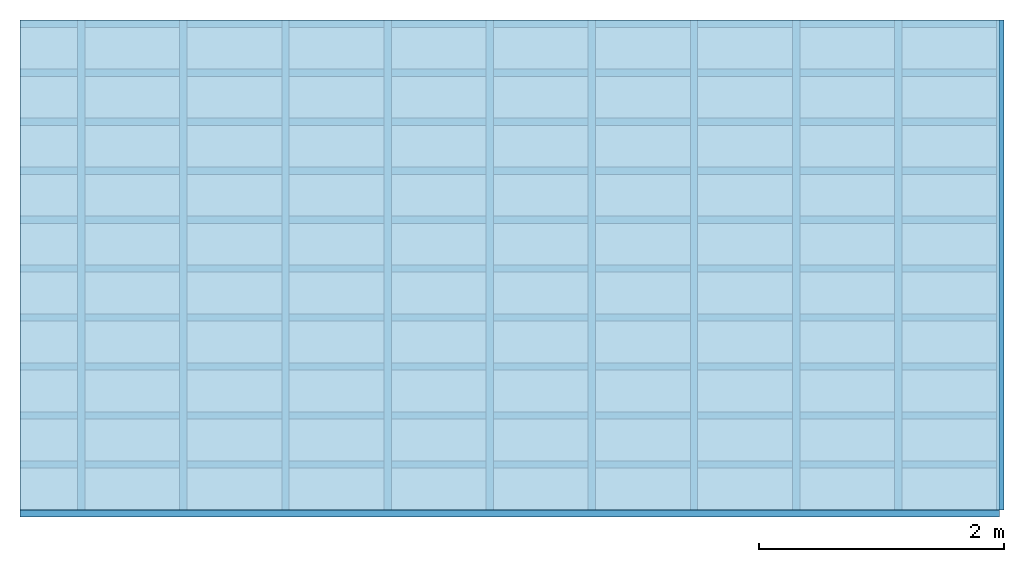
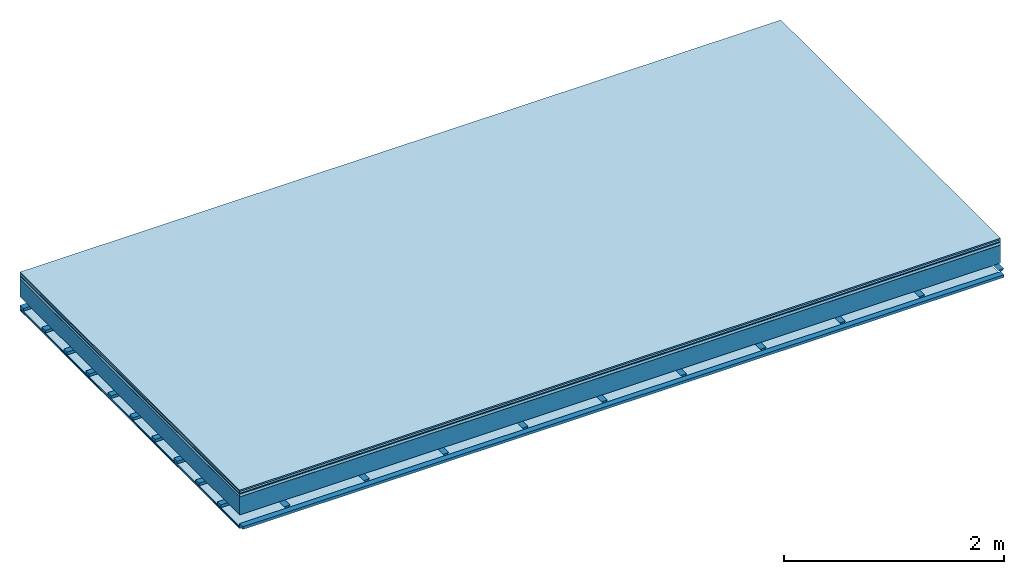
# One storey: 8 plates, 3 members, 1 element without a shape of its own.
"""IFC4 building model written with IfcOpenShell, lengths in metres."""

from ifc_helpers import new_model, si_unit, derived_unit, direction, frame, frame_2d, origin, origin_with_axes, place, context, project, spatial, polyline, rectangle, outline, extrude, material, layer, layer_set, type_object, element, aggregate, save


model = new_model("IFC4")

# Units and contexts
plan_context = context("Plan", 3, precision=1e-05, world=origin(), true_north=direction((0.0, 1.0)))
model_context = context("Model", 3, precision=1e-05, world=origin(), true_north=direction((0.0, 1.0)))
ifc_project = project(units=[si_unit("LENGTHUNIT", "METRE"), derived_unit("SOUNDPRESSUREUNIT", [(si_unit("PRESSUREUNIT", "PASCAL", prefix="MICRO"), 0)]), si_unit("ENERGYUNIT", "JOULE", prefix="MEGA"), si_unit("MASSUNIT", "GRAM", prefix="KILO"), derived_unit("THERMALTRANSMITTANCEUNIT", [(si_unit("POWERUNIT", "WATT"), 1), (si_unit("AREAUNIT", "SQUARE_METRE"), -1), (si_unit("THERMODYNAMICTEMPERATUREUNIT", "KELVIN"), -1)]), derived_unit("AREADENSITYUNIT", [(si_unit("MASSUNIT", "GRAM", prefix="KILO"), 1), (si_unit("AREAUNIT", "SQUARE_METRE"), -1)]), derived_unit("USERDEFINED", [(si_unit("ENERGYUNIT", "JOULE", prefix="MEGA"), 1), (si_unit("AREAUNIT", "SQUARE_METRE"), -1)])], contexts=[plan_context, model_context])

# Site, building, storey
site = spatial("IfcSite", under=ifc_project)
building_placement = place(None, origin())
building = spatial("IfcBuilding", under=site, at=building_placement)
storey_placement = place(building_placement, origin())
storey = spatial("IfcBuildingStorey", under=building, at=storey_placement)

# Slab, members, plates
ifc_material_1 = material(Category="11.013")
ifc_layer_1 = layer(ifc_material_1, 0.015, Name="Flooring")
ifc_material_2 = material(Category="03.007")
ifc_layer_2 = layer(ifc_material_2, 0.02, Name="On-material")
ifc_material_3 = material(Name="Wood fiber generic product", Category="10.009")
ifc_layer_3 = layer(ifc_material_3, 0.01, Name="Impact sound insulation")
ifc_material_4 = material(Name="with broken")
ifc_layer_4 = layer(ifc_material_4, 0.03, Name="on Supporting structure")
ifc_material_5 = material(Name="protection", Category="09.007")
ifc_layer_5 = layer(ifc_material_5, 0.0005, Name="Sub-floor")
ifc_material_6 = material(Name="no composite action")
ifc_layer_6 = layer(ifc_material_6, 0.0, Name="Bond")
ifc_layer_7 = layer(None, 0.2, Name="Supporting structure")
ifc_layer_8 = layer(ifc_material_6, 0.0, Name="Bond")
ifc_layer_9 = layer(None, 0.095, Name="Coupling")
ifc_layer_10 = layer(None, 0.03, Name="Battens / profiles")
ifc_material_7 = material(Name="Plasterboard type A", Category="03.008")
ifc_layer_11 = layer(ifc_material_7, 0.0125, Name="Ceiling covering 1st layer")
ifc_layer_12 = layer(ifc_material_7, 0.0125, Name="Ceiling covering layer 2")
ifc_material_8 = material(Category="04.001")
ifc_layer_13 = layer(ifc_material_8, 0.003, Name="Surface / treatment")
ifc_layer_set = layer_set([ifc_layer_1, ifc_layer_2, ifc_layer_3, ifc_layer_4, ifc_layer_5, ifc_layer_6, ifc_layer_7, ifc_layer_8, ifc_layer_9, ifc_layer_10, ifc_layer_11, ifc_layer_12, ifc_layer_13])
slab_type = type_object("IfcSlabType", Name="A2118", PredefinedType="NOTDEFINED", material=ifc_layer_set)
slab_placement = place(None, frame((0.0, 0.0, 0.0), z_axis=(0.0, 0.0, -1.0), x_axis=(1.0, 0.0, 0.0)))
slab = element("IfcSlab", 1, at=slab_placement, inside=storey, type_object=slab_type, material=ifc_layer_set, Name="Slab #1")
ifc_material_9 = material(Name="Solid timber panel")
member_1_placement = place(slab_placement, origin())
member_1 = element("IfcMember", 2, at=member_1_placement, material=ifc_material_9, Name="Supporting structure", context=plan_context, shape_type="SweptSolid", body=[
    extrude(rectangle(XDim=1.0, YDim=0.2, at=frame_2d((0.5, 0.1), x_axis=(1.0, 0.0))), frame((0.0, 4.0, 0.0755), z_axis=(0.0, -1.0, 0.0), x_axis=(1.0, 0.0, 0.0)), (0.0, 0.0, 1.0), 4.0),
    extrude(rectangle(XDim=1.0, YDim=0.2, at=frame_2d((0.5, 0.1), x_axis=(1.0, 0.0))), frame((1.0, 4.0, 0.0755), z_axis=(0.0, -1.0, 0.0), x_axis=(1.0, 0.0, 0.0)), (0.0, 0.0, 1.0), 4.0),
    extrude(rectangle(XDim=1.0, YDim=0.2, at=frame_2d((0.5, 0.1), x_axis=(1.0, 0.0))), frame((2.0, 4.0, 0.0755), z_axis=(0.0, -1.0, 0.0), x_axis=(1.0, 0.0, 0.0)), (0.0, 0.0, 1.0), 4.0),
    extrude(rectangle(XDim=1.0, YDim=0.2, at=frame_2d((0.5, 0.1), x_axis=(1.0, 0.0))), frame((3.0, 4.0, 0.0755), z_axis=(0.0, -1.0, 0.0), x_axis=(1.0, 0.0, 0.0)), (0.0, 0.0, 1.0), 4.0),
    extrude(rectangle(XDim=1.0, YDim=0.2, at=frame_2d((0.5, 0.1), x_axis=(1.0, 0.0))), frame((4.0, 4.0, 0.0755), z_axis=(0.0, -1.0, 0.0), x_axis=(1.0, 0.0, 0.0)), (0.0, 0.0, 1.0), 4.0),
    extrude(rectangle(XDim=1.0, YDim=0.2, at=frame_2d((0.5, 0.1), x_axis=(1.0, 0.0))), frame((5.0, 4.0, 0.0755), z_axis=(0.0, -1.0, 0.0), x_axis=(1.0, 0.0, 0.0)), (0.0, 0.0, 1.0), 4.0),
    extrude(rectangle(XDim=1.0, YDim=0.2, at=frame_2d((0.5, 0.1), x_axis=(1.0, 0.0))), frame((6.0, 4.0, 0.0755), z_axis=(0.0, -1.0, 0.0), x_axis=(1.0, 0.0, 0.0)), (0.0, 0.0, 1.0), 4.0),
    extrude(rectangle(XDim=1.0, YDim=0.2, at=frame_2d((0.5, 0.1), x_axis=(1.0, 0.0))), frame((7.0, 4.0, 0.0755), z_axis=(0.0, -1.0, 0.0), x_axis=(1.0, 0.0, 0.0)), (0.0, 0.0, 1.0), 4.0),
])
ifc_material_10 = material()
member_2_placement = place(slab_placement, origin())
member_2 = element("IfcMember", 3, at=member_2_placement, material=ifc_material_10, Name="Coupling", context=plan_context, shape_type="SweptSolid", body=[
    extrude(outline(polyline([(0.0, 0.0), (0.06, 0.0), (0.04, 0.02), (0.02, 0.02), (0.0, 0.0)])), frame((0.47, 4.0, 0.3505), z_axis=(0.0, -1.0, 0.0), x_axis=(1.0, 0.0, 0.0)), (0.0, 0.0, 1.0), 4.0),
    extrude(outline(polyline([(0.0, 0.0), (0.06, 0.0), (0.04, 0.02), (0.02, 0.02), (0.0, 0.0)])), frame((1.304, 4.0, 0.3505), z_axis=(0.0, -1.0, 0.0), x_axis=(1.0, 0.0, 0.0)), (0.0, 0.0, 1.0), 4.0),
    extrude(outline(polyline([(0.0, 0.0), (0.06, 0.0), (0.04, 0.02), (0.02, 0.02), (0.0, 0.0)])), frame((2.138, 4.0, 0.3505), z_axis=(0.0, -1.0, 0.0), x_axis=(1.0, 0.0, 0.0)), (0.0, 0.0, 1.0), 4.0),
    extrude(outline(polyline([(0.0, 0.0), (0.06, 0.0), (0.04, 0.02), (0.02, 0.02), (0.0, 0.0)])), frame((2.972, 4.0, 0.3505), z_axis=(0.0, -1.0, 0.0), x_axis=(1.0, 0.0, 0.0)), (0.0, 0.0, 1.0), 4.0),
    extrude(outline(polyline([(0.0, 0.0), (0.06, 0.0), (0.04, 0.02), (0.02, 0.02), (0.0, 0.0)])), frame((3.806, 4.0, 0.3505), z_axis=(0.0, -1.0, 0.0), x_axis=(1.0, 0.0, 0.0)), (0.0, 0.0, 1.0), 4.0),
    extrude(outline(polyline([(0.0, 0.0), (0.06, 0.0), (0.04, 0.02), (0.02, 0.02), (0.0, 0.0)])), frame((4.64, 4.0, 0.3505), z_axis=(0.0, -1.0, 0.0), x_axis=(1.0, 0.0, 0.0)), (0.0, 0.0, 1.0), 4.0),
    extrude(outline(polyline([(0.0, 0.0), (0.06, 0.0), (0.04, 0.02), (0.02, 0.02), (0.0, 0.0)])), frame((5.474, 4.0, 0.3505), z_axis=(0.0, -1.0, 0.0), x_axis=(1.0, 0.0, 0.0)), (0.0, 0.0, 1.0), 4.0),
    extrude(outline(polyline([(0.0, 0.0), (0.06, 0.0), (0.04, 0.02), (0.02, 0.02), (0.0, 0.0)])), frame((6.308, 4.0, 0.3505), z_axis=(0.0, -1.0, 0.0), x_axis=(1.0, 0.0, 0.0)), (0.0, 0.0, 1.0), 4.0),
    extrude(outline(polyline([(0.0, 0.0), (0.06, 0.0), (0.04, 0.02), (0.02, 0.02), (0.0, 0.0)])), frame((7.142, 4.0, 0.3505), z_axis=(0.0, -1.0, 0.0), x_axis=(1.0, 0.0, 0.0)), (0.0, 0.0, 1.0), 4.0),
    extrude(outline(polyline([(0.0, 0.0), (0.06, 0.0), (0.04, 0.02), (0.02, 0.02), (0.0, 0.0)])), frame((7.976, 4.0, 0.3505), z_axis=(0.0, -1.0, 0.0), x_axis=(1.0, 0.0, 0.0)), (0.0, 0.0, 1.0), 4.0),
])
member_3_placement = place(slab_placement, origin())
member_3 = element("IfcMember", 4, at=member_3_placement, material=ifc_material_10, Name="Battens / profiles", context=plan_context, shape_type="SweptSolid", body=[
    extrude(rectangle(XDim=0.06, YDim=0.03, at=frame_2d((0.03, 0.015), x_axis=(1.0, 0.0))), frame((0.0, 0.0, 0.3705), z_axis=(1.0, 0.0, 0.0), x_axis=(0.0, 1.0, 0.0)), (0.0, 0.0, 1.0), 8.0),
    extrude(rectangle(XDim=0.06, YDim=0.03, at=frame_2d((0.03, 0.015), x_axis=(1.0, 0.0))), frame((0.0, 0.4, 0.3705), z_axis=(1.0, 0.0, 0.0), x_axis=(0.0, 1.0, 0.0)), (0.0, 0.0, 1.0), 8.0),
    extrude(rectangle(XDim=0.06, YDim=0.03, at=frame_2d((0.03, 0.015), x_axis=(1.0, 0.0))), frame((0.0, 0.8, 0.3705), z_axis=(1.0, 0.0, 0.0), x_axis=(0.0, 1.0, 0.0)), (0.0, 0.0, 1.0), 8.0),
    extrude(rectangle(XDim=0.06, YDim=0.03, at=frame_2d((0.03, 0.015), x_axis=(1.0, 0.0))), frame((0.0, 1.2, 0.3705), z_axis=(1.0, 0.0, 0.0), x_axis=(0.0, 1.0, 0.0)), (0.0, 0.0, 1.0), 8.0),
    extrude(rectangle(XDim=0.06, YDim=0.03, at=frame_2d((0.03, 0.015), x_axis=(1.0, 0.0))), frame((0.0, 1.6, 0.3705), z_axis=(1.0, 0.0, 0.0), x_axis=(0.0, 1.0, 0.0)), (0.0, 0.0, 1.0), 8.0),
    extrude(rectangle(XDim=0.06, YDim=0.03, at=frame_2d((0.03, 0.015), x_axis=(1.0, 0.0))), frame((0.0, 2.0, 0.3705), z_axis=(1.0, 0.0, 0.0), x_axis=(0.0, 1.0, 0.0)), (0.0, 0.0, 1.0), 8.0),
    extrude(rectangle(XDim=0.06, YDim=0.03, at=frame_2d((0.03, 0.015), x_axis=(1.0, 0.0))), frame((0.0, 2.4, 0.3705), z_axis=(1.0, 0.0, 0.0), x_axis=(0.0, 1.0, 0.0)), (0.0, 0.0, 1.0), 8.0),
    extrude(rectangle(XDim=0.06, YDim=0.03, at=frame_2d((0.03, 0.015), x_axis=(1.0, 0.0))), frame((0.0, 2.8, 0.3705), z_axis=(1.0, 0.0, 0.0), x_axis=(0.0, 1.0, 0.0)), (0.0, 0.0, 1.0), 8.0),
    extrude(rectangle(XDim=0.06, YDim=0.03, at=frame_2d((0.03, 0.015), x_axis=(1.0, 0.0))), frame((0.0, 3.2, 0.3705), z_axis=(1.0, 0.0, 0.0), x_axis=(0.0, 1.0, 0.0)), (0.0, 0.0, 1.0), 8.0),
    extrude(rectangle(XDim=0.06, YDim=0.03, at=frame_2d((0.03, 0.015), x_axis=(1.0, 0.0))), frame((0.0, 3.6, 0.3705), z_axis=(1.0, 0.0, 0.0), x_axis=(0.0, 1.0, 0.0)), (0.0, 0.0, 1.0), 8.0),
    extrude(rectangle(XDim=0.06, YDim=0.03, at=frame_2d((0.03, 0.015), x_axis=(1.0, 0.0))), frame((0.0, 4.0, 0.3705), z_axis=(1.0, 0.0, 0.0), x_axis=(0.0, 1.0, 0.0)), (0.0, 0.0, 1.0), 8.0),
])
plate_1_placement = place(slab_placement, origin())
plate_1 = element("IfcPlate", 5, at=plate_1_placement, material=ifc_material_1, Name="Flooring", context=plan_context, shape_type="SweptSolid", body=[
    extrude(rectangle(XDim=8.0, YDim=4.0, at=frame_2d((4.0, 2.0), x_axis=(1.0, 0.0))), origin_with_axes(), (0.0, 0.0, 1.0), 0.015),
])
plate_2_placement = place(slab_placement, origin())
plate_2 = element("IfcPlate", 6, at=plate_2_placement, material=ifc_material_2, Name="On-material", context=plan_context, shape_type="SweptSolid", body=[
    extrude(rectangle(XDim=8.0, YDim=4.0, at=frame_2d((4.0, 2.0), x_axis=(1.0, 0.0))), frame((0.0, 0.0, 0.015), z_axis=(0.0, 0.0, 1.0), x_axis=(1.0, 0.0, 0.0)), (0.0, 0.0, 1.0), 0.02),
])
plate_3_placement = place(slab_placement, origin())
plate_3 = element("IfcPlate", 7, at=plate_3_placement, material=ifc_material_3, Name="Impact sound insulation", context=plan_context, shape_type="SweptSolid", body=[
    extrude(rectangle(XDim=8.0, YDim=4.0, at=frame_2d((4.0, 2.0), x_axis=(1.0, 0.0))), frame((0.0, 0.0, 0.035), z_axis=(0.0, 0.0, 1.0), x_axis=(1.0, 0.0, 0.0)), (0.0, 0.0, 1.0), 0.01),
])
plate_4_placement = place(slab_placement, origin())
plate_4 = element("IfcPlate", 8, at=plate_4_placement, material=ifc_material_4, Name="on Supporting structure", context=plan_context, shape_type="SweptSolid", body=[
    extrude(rectangle(XDim=8.0, YDim=4.0, at=frame_2d((4.0, 2.0), x_axis=(1.0, 0.0))), frame((0.0, 0.0, 0.045), z_axis=(0.0, 0.0, 1.0), x_axis=(1.0, 0.0, 0.0)), (0.0, 0.0, 1.0), 0.03),
])
plate_5_placement = place(slab_placement, origin())
plate_5 = element("IfcPlate", 9, at=plate_5_placement, material=ifc_material_5, Name="Sub-floor", context=plan_context, shape_type="SweptSolid", body=[
    extrude(rectangle(XDim=8.0, YDim=4.0, at=frame_2d((4.0, 2.0), x_axis=(1.0, 0.0))), frame((0.0, 0.0, 0.075), z_axis=(0.0, 0.0, 1.0), x_axis=(1.0, 0.0, 0.0)), (0.0, 0.0, 1.0), 0.0005),
])
plate_6_placement = place(slab_placement, origin())
plate_6 = element("IfcPlate", 10, at=plate_6_placement, material=ifc_material_7, Name="Ceiling covering 1st layer", context=plan_context, shape_type="SweptSolid", body=[
    extrude(rectangle(XDim=8.0, YDim=4.0, at=frame_2d((4.0, 2.0), x_axis=(1.0, 0.0))), frame((0.0, 0.0, 0.4005), z_axis=(0.0, 0.0, 1.0), x_axis=(1.0, 0.0, 0.0)), (0.0, 0.0, 1.0), 0.0125),
])
plate_7_placement = place(slab_placement, origin())
plate_7 = element("IfcPlate", 11, at=plate_7_placement, material=ifc_material_7, Name="Ceiling covering layer 2", context=plan_context, shape_type="SweptSolid", body=[
    extrude(rectangle(XDim=8.0, YDim=4.0, at=frame_2d((4.0, 2.0), x_axis=(1.0, 0.0))), frame((0.0, 0.0, 0.413), z_axis=(0.0, 0.0, 1.0), x_axis=(1.0, 0.0, 0.0)), (0.0, 0.0, 1.0), 0.0125),
])
plate_8_placement = place(slab_placement, origin())
plate_8 = element("IfcPlate", 12, at=plate_8_placement, material=ifc_material_8, Name="Surface / treatment", context=plan_context, shape_type="SweptSolid", body=[
    extrude(rectangle(XDim=8.0, YDim=4.0, at=frame_2d((4.0, 2.0), x_axis=(1.0, 0.0))), frame((0.0, 0.0, 0.4255), z_axis=(0.0, 0.0, 1.0), x_axis=(1.0, 0.0, 0.0)), (0.0, 0.0, 1.0), 0.003),
])
aggregate(slab, [plate_1, plate_2, plate_3, plate_4, plate_5, member_1, member_2, member_3, plate_6, plate_7, plate_8])

save(model, "model.ifc")
